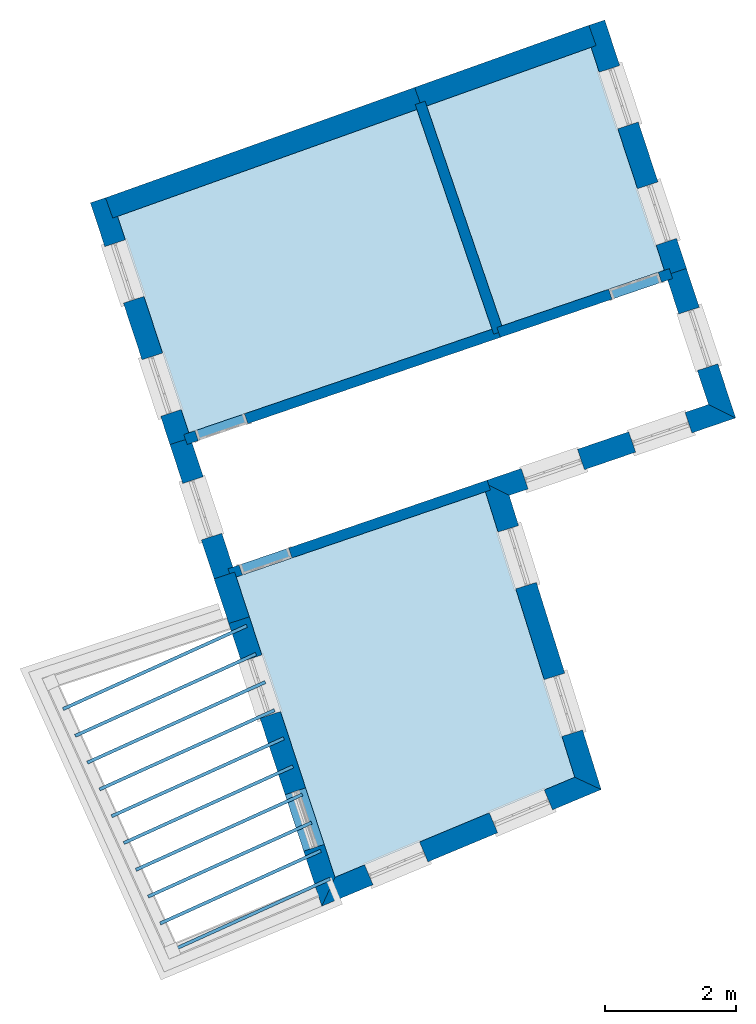
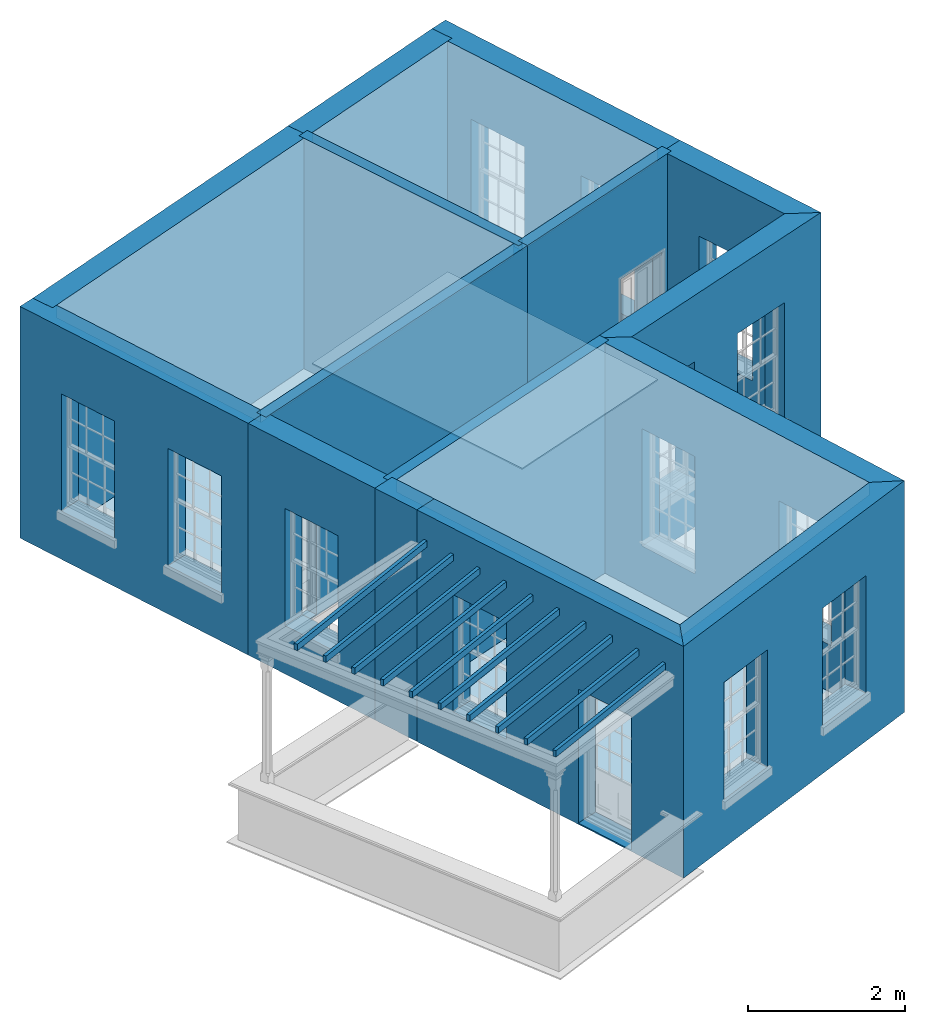
# One storey, part 1 of 10: 16 slabs, 15 walls, 17 openings.
"""IFC2X3 building model written with IfcOpenShell, lengths in metres."""

import ifcopenshell
import ifcopenshell.guid

model = None  # the IFC model being written
_history = None  # IfcOwnerHistory: only IFC2X3 demands one
_inside = {}  # id of a spatial element -> (the spatial element, [elements in it])
_under = {}  # id of a project, library or spatial element -> (it, [spatial elements below it])
_declared = {}  # id of a project -> (the project, [libraries it declares])
_typed = {}  # id of a type object -> (the type object, [elements of that type])
_made_of = {}  # id of a material, layer set ... -> (it, [elements and type objects made of it])


def new_model(schema):
    """Start an empty IFC model of exactly this schema.

    Asked for "IFC4X3", IfcOpenShell would pick the latest addendum, in which some entities
    have other attributes; the version numbers below select the first issue.
    IFC2X3 requires an IfcOwnerHistory on every rooted entity: one is made here for all.
    """
    global model, _history
    if schema == "IFC4X3":
        model = ifcopenshell.file(schema_version=(4, 3, 0, 0))
    else:
        model = ifcopenshell.file(schema=schema)
    _inside.clear()
    _under.clear()
    _declared.clear()
    _typed.clear()
    _made_of.clear()
    _history = None
    if model.schema == "IFC2X3":
        org = make("IfcOrganization", Name="unknown")
        user = make(
            "IfcPersonAndOrganization",
            ThePerson=make("IfcPerson", FamilyName="unknown"),
            TheOrganization=org,
        )
        app = make(
            "IfcApplication",
            ApplicationDeveloper=org,
            Version="unknown",
            ApplicationFullName="unknown",
            ApplicationIdentifier="unknown",
        )
        _history = make(
            "IfcOwnerHistory",
            OwningUser=user,
            OwningApplication=app,
            ChangeAction="ADDED",
            CreationDate=0,
        )
    return model


def make(cls, **values):
    """One entity of the class cls with the attributes given. An attribute that is None is left unset."""
    return model.create_entity(
        cls, **{name: value for name, value in values.items() if value is not None}
    )


def rooted(cls, **values):
    """An entity with a GlobalId (a new one), such as an element, a storey or a relation."""
    return make(cls, GlobalId=ifcopenshell.guid.new(), OwnerHistory=_history, **values)


def si_unit(unit_type, name, prefix=None):
    """IfcSIUnit, for example si_unit("LENGTHUNIT", "METRE", prefix="MILLI")."""
    return make("IfcSIUnit", UnitType=unit_type, Prefix=prefix, Name=name)


def assignment(units):
    """IfcUnitAssignment: the units of a project."""
    return None if units is None else make("IfcUnitAssignment", Units=units)


def point(xyz):
    """IfcCartesianPoint."""
    return None if xyz is None else make("IfcCartesianPoint", Coordinates=xyz)


def direction(xyz):
    """IfcDirection."""
    return None if xyz is None else make("IfcDirection", DirectionRatios=xyz)


def frame(location, z_axis=None, x_axis=None):
    """IfcAxis2Placement3D, a coordinate frame: its origin and axes. An axis left out is left unset."""
    return make(
        "IfcAxis2Placement3D",
        Location=point(location),
        Axis=direction(z_axis),
        RefDirection=direction(x_axis),
    )


def origin():
    """The frame at (0, 0, 0) with its axes left unset."""
    return frame((0.0, 0.0, 0.0))


def place(relative_to, where):
    """IfcLocalPlacement: puts the frame where relative to a parent placement (None: the world)."""
    return make(
        "IfcLocalPlacement", PlacementRelTo=relative_to, RelativePlacement=where
    )


def context(
    kind, dimensions, precision=None, world=None, true_north=None, identifier=None
):
    """IfcGeometricRepresentationContext, for example the 3D "Model" context."""
    return make(
        "IfcGeometricRepresentationContext",
        ContextIdentifier=identifier,
        ContextType=kind,
        CoordinateSpaceDimension=dimensions,
        Precision=precision,
        WorldCoordinateSystem=world,
        TrueNorth=true_north,
    )


def subcontext(parent, identifier, kind, view, scale=None):
    """IfcGeometricRepresentationSubContext, for example "Body" below "Model"."""
    return make(
        "IfcGeometricRepresentationSubContext",
        ContextIdentifier=identifier,
        ContextType=kind,
        ParentContext=parent,
        TargetScale=scale,
        TargetView=view,
    )


def project(units=None, contexts=None):
    """IfcProject with its units and contexts."""
    return rooted(
        "IfcProject",
        Name="project",
        RepresentationContexts=contexts,
        UnitsInContext=assignment(units),
    )


def spatial(cls, under=None, at=None, **own):
    """A site, building, storey or space (cls), placed at a placement, below another one or the project."""
    s = rooted(cls, ObjectPlacement=at, **own)
    if under is not None:
        _under.setdefault(under.id(), (under, []))[1].append(s)
    return s


def polyline(points):
    """IfcPolyline through the points."""
    return make("IfcPolyline", Points=[point(p) for p in points])


def outline(outer, holes=None, kind="AREA"):
    """IfcArbitraryClosedProfileDef: a profile drawn as a closed curve; with holes, ...WithVoids."""
    if holes is None:
        return make("IfcArbitraryClosedProfileDef", ProfileType=kind, OuterCurve=outer)
    return make(
        "IfcArbitraryProfileDefWithVoids",
        ProfileType=kind,
        OuterCurve=outer,
        InnerCurves=holes,
    )


def extrude(swept, where, along, depth):
    """IfcExtrudedAreaSolid: the profile swept, set in the frame where, extruded along a direction by depth."""
    return make(
        "IfcExtrudedAreaSolid",
        SweptArea=swept,
        Position=where,
        ExtrudedDirection=direction(along),
        Depth=depth,
    )


def shape(context_of_items, identifier, shape_type, items):
    """IfcShapeRepresentation: the items that make up one representation, for example the "Body"."""
    return make(
        "IfcShapeRepresentation",
        ContextOfItems=context_of_items,
        RepresentationIdentifier=identifier,
        RepresentationType=shape_type,
        Items=items,
    )


def material(Name=None, Category=None):
    """IfcMaterial."""
    return make("IfcMaterial", Name=Name, Category=Category)


def layer(
    of_material, thickness, ventilated=None, Name=None, Category=None, Priority=None
):
    """IfcMaterialLayer: one layer of a wall or slab, of a material (None: an air gap)."""
    return make(
        "IfcMaterialLayer",
        Material=of_material,
        LayerThickness=thickness,
        IsVentilated=ventilated,
        Name=Name,
        Category=Category,
        Priority=Priority,
    )


def layer_set(layers, Name=None):
    """IfcMaterialLayerSet."""
    return make("IfcMaterialLayerSet", MaterialLayers=layers, LayerSetName=Name)


def layer_usage(for_layer_set, set_direction, sense, offset, extent=None):
    """IfcMaterialLayerSetUsage: how a layer set lies in its element."""
    return make(
        "IfcMaterialLayerSetUsage",
        ForLayerSet=for_layer_set,
        LayerSetDirection=set_direction,
        DirectionSense=sense,
        OffsetFromReferenceLine=offset,
        ReferenceExtent=extent,
    )


def made_of(thing, what):
    """Note that an element or type object is made of a material, layer set ...; save() writes the relation."""
    if what is not None:
        _made_of.setdefault(what.id(), (what, []))[1].append(thing)
    return thing


def element(
    cls,
    number,
    at=None,
    inside=None,
    cuts=None,
    type_object=None,
    material=None,
    context=None,
    identifier="Body",
    shape_type=None,
    held_by="IfcProductDefinitionShape",
    body=None,
    shapes=None,
    **own,
):
    """One element of the class cls, such as IfcWall. Its Tag is "e" and its number.

    at: its placement. inside: the storey or other place that contains it. cuts: it is an
    opening in that element (IfcRelVoidsElement). A single representation is given by context,
    identifier, shape_type and body (its items); several are given by shapes. held_by: the class
    of the entity that holds the representations. save() writes the other relations.
    """
    e = rooted(cls, Tag="e%d" % number, ObjectPlacement=at, **own)
    if body is not None:
        shapes = [shape(context, identifier, shape_type, body)]
    if shapes is not None:
        e.Representation = make(held_by, Representations=shapes)
    if inside is not None:
        _inside.setdefault(inside.id(), (inside, []))[1].append(e)
    if cuts is not None:
        rooted(
            "IfcRelVoidsElement", RelatingBuildingElement=cuts, RelatedOpeningElement=e
        )
    if type_object is not None:
        _typed.setdefault(type_object.id(), (type_object, []))[1].append(e)
    return made_of(e, material)


def aggregate(whole, parts):
    """IfcRelAggregates: a whole, such as a stair, and the parts it consists of."""
    return rooted("IfcRelAggregates", RelatingObject=whole, RelatedObjects=parts)


def save(model, path):
    """Write the relations noted so far, then the file.

    IfcRelAggregates (storeys below a building ...), IfcRelContainedInSpatialStructure (elements
    in a storey), IfcRelDefinesByType, IfcRelAssociatesMaterial and IfcRelDeclares: one each for
    every whole, place, type object, material and project.
    """
    for whole, parts in _under.values():
        aggregate(whole, parts)
    for where, things in _inside.values():
        rooted(
            "IfcRelContainedInSpatialStructure",
            RelatedElements=things,
            RelatingStructure=where,
        )
    for kind, things in _typed.values():
        rooted("IfcRelDefinesByType", RelatedObjects=things, RelatingType=kind)
    for what, things in _made_of.values():
        rooted("IfcRelAssociatesMaterial", RelatedObjects=things, RelatingMaterial=what)
    for by, libraries in _declared.values():
        rooted("IfcRelDeclares", RelatingContext=by, RelatedDefinitions=libraries)
    model.write(path)


model = new_model("IFC2X3")

# Units and contexts
model_context = context("Model", 3, world=origin())
body_context = subcontext(model_context, "Body", "Model", "MODEL_VIEW")
ifc_project = project(units=[si_unit("PLANEANGLEUNIT", "RADIAN"), si_unit("MASSUNIT", "GRAM", prefix="KILO"), si_unit("FORCEUNIT", "NEWTON", prefix="KILO"), si_unit("LENGTHUNIT", "METRE")], contexts=[model_context])

# Site, building, storey
site_placement = place(None, origin())
site = spatial("IfcSite", under=ifc_project, at=site_placement, CompositionType="ELEMENT")
building_placement = place(None, origin())
building = spatial("IfcBuilding", under=site, at=building_placement, Name="Building plot-2", CompositionType="ELEMENT")
storey_placement = place(None, frame((0.0, 0.0, 4.6)))
storey = spatial("IfcBuildingStorey", under=building, at=storey_placement, Name="Floor 1", CompositionType="ELEMENT", Elevation=4.6)

# Slabs
slab_1_placement = place(storey_placement, frame((0.0, 0.0, 3.4)))
element("IfcSlab", 1, at=slab_1_placement, inside=storey, Name="Slab", ObjectType="Slab", PredefinedType="FLOOR", context=body_context, shape_type="SweptSolid", body=[
    extrude(outline(polyline([(33.5290367019011, 35.1153902275638), (36.0140572668092, 35.9650779065647), (34.8926468518954, 39.3738287255257), (32.3797022245849, 38.4767662751101), (33.5290367019011, 35.1153902275638)])), origin(), (0.0, 0.0, 1.0), 0.2),
])
slab_2_placement = place(storey_placement, frame((0.0, 0.0, 3.4)))
element("IfcSlab", 2, at=slab_2_placement, inside=storey, Name="Slab", ObjectType="Slab", PredefinedType="FLOOR", context=body_context, shape_type="SweptSolid", body=[
    extrude(outline(polyline([(30.9770364314834, 26.681595071692), (34.6434756954392, 28.211451652365), (33.2776509706579, 32.5768775648318), (29.4663278228958, 31.2736954644197), (30.9770364314834, 26.681595071692)])), origin(), (0.0, 0.0, 1.0), 0.2),
])
slab_3_placement = place(storey_placement, frame((0.0, 0.0, 3.4)))
element("IfcSlab", 3, at=slab_3_placement, inside=storey, Name="Slab", ObjectType="Slab", PredefinedType="FLOOR", context=body_context, shape_type="SweptSolid", body=[
    extrude(outline(polyline([(28.7410673229935, 33.4782695348257), (33.3776420525997, 35.0636247935088), (32.2290020264794, 38.4229698294896), (27.6518880966078, 36.7890472220676), (28.7410673229935, 33.4782695348257)])), origin(), (0.0, 0.0, 1.0), 0.2),
])
slab_4_placement = place(storey_placement, frame((0.0, 0.0, 3.1)))
element("IfcSlab", 4, at=slab_4_placement, inside=storey, Name="Slab", ObjectType="Slab", PredefinedType="FLOOR", context=body_context, shape_type="SweptSolid", body=[
    extrude(outline(polyline([(26.8073450307166, 29.2772545120461), (26.8279720766327, 29.2317075585061), (29.6380417777998, 30.5043159823061), (29.6174147318837, 30.5498629358461), (26.8073450307166, 29.2772545120461)])), origin(), (0.0, 0.0, 1.0), 0.1),
])
slab_5_placement = place(storey_placement, frame((0.0, 0.0, 3.1)))
element("IfcSlab", 5, at=slab_5_placement, inside=storey, Name="Slab", ObjectType="Slab", PredefinedType="FLOOR", context=body_context, shape_type="SweptSolid", body=[
    extrude(outline(polyline([(26.9929884439615, 28.8673319301861), (27.0136154898777, 28.8217849766461), (29.7794835122652, 30.0743755949313), (29.7588564663491, 30.1199225484713), (26.9929884439615, 28.8673319301861)])), origin(), (0.0, 0.0, 1.0), 0.1),
])
slab_6_placement = place(storey_placement, frame((0.0, 0.0, 3.1)))
element("IfcSlab", 6, at=slab_6_placement, inside=storey, Name="Slab", ObjectType="Slab", PredefinedType="FLOOR", context=body_context, shape_type="SweptSolid", body=[
    extrude(outline(polyline([(27.1786318572065, 28.4574093483261), (27.1992589031226, 28.4118623947861), (29.9209252467306, 29.6444352075565), (29.9002982008145, 29.6899821610965), (27.1786318572065, 28.4574093483261)])), origin(), (0.0, 0.0, 1.0), 0.1),
])
slab_7_placement = place(storey_placement, frame((0.0, 0.0, 3.1)))
element("IfcSlab", 7, at=slab_7_placement, inside=storey, Name="Slab", ObjectType="Slab", PredefinedType="FLOOR", context=body_context, shape_type="SweptSolid", body=[
    extrude(outline(polyline([(27.3642752704514, 28.0474867664661), (27.3849023163675, 28.0019398129261), (30.062366981196, 29.2144948201818), (30.0417399352799, 29.2600417737218), (27.3642752704514, 28.0474867664661)])), origin(), (0.0, 0.0, 1.0), 0.1),
])
slab_8_placement = place(storey_placement, frame((0.0, 0.0, 3.1)))
element("IfcSlab", 8, at=slab_8_placement, inside=storey, Name="Slab", ObjectType="Slab", PredefinedType="FLOOR", context=body_context, shape_type="SweptSolid", body=[
    extrude(outline(polyline([(27.5499186836964, 27.6375641846061), (27.5705457296125, 27.5920172310661), (30.2038087156614, 28.784554432807), (30.1831816697453, 28.830101386347), (27.5499186836964, 27.6375641846061)])), origin(), (0.0, 0.0, 1.0), 0.1),
])
slab_9_placement = place(storey_placement, frame((0.0, 0.0, 3.1)))
element("IfcSlab", 9, at=slab_9_placement, inside=storey, Name="Slab", ObjectType="Slab", PredefinedType="FLOOR", context=body_context, shape_type="SweptSolid", body=[
    extrude(outline(polyline([(27.7355620969413, 27.2276416027461), (27.7561891428574, 27.1820946492061), (30.3452504501268, 28.3546140454322), (30.3246234042107, 28.4001609989722), (27.7355620969413, 27.2276416027461)])), origin(), (0.0, 0.0, 1.0), 0.1),
])
slab_10_placement = place(storey_placement, frame((0.0, 0.0, 3.1)))
element("IfcSlab", 10, at=slab_10_placement, inside=storey, Name="Slab", ObjectType="Slab", PredefinedType="FLOOR", context=body_context, shape_type="SweptSolid", body=[
    extrude(outline(polyline([(27.9212055101863, 26.8177190208861), (27.9418325561024, 26.7721720673461), (30.4866921845922, 27.9246736580574), (30.4660651386761, 27.9702206115974), (27.9212055101863, 26.8177190208861)])), origin(), (0.0, 0.0, 1.0), 0.1),
])
slab_11_placement = place(storey_placement, frame((0.0, 0.0, 3.1)))
element("IfcSlab", 11, at=slab_11_placement, inside=storey, Name="Slab", ObjectType="Slab", PredefinedType="FLOOR", context=body_context, shape_type="SweptSolid", body=[
    extrude(outline(polyline([(28.1068489234312, 26.4077964390261), (28.1274759693473, 26.3622494854861), (30.6281339190576, 27.4947332706826), (30.6075068731415, 27.5402802242226), (28.1068489234312, 26.4077964390261)])), origin(), (0.0, 0.0, 1.0), 0.1),
])
slab_12_placement = place(storey_placement, frame((0.0, 0.0, 3.1)))
element("IfcSlab", 12, at=slab_12_placement, inside=storey, Name="Slab", ObjectType="Slab", PredefinedType="FLOOR", context=body_context, shape_type="SweptSolid", body=[
    extrude(outline(polyline([(28.2924923366762, 25.9978738571661), (28.3131193825923, 25.9523269036261), (30.7695756535229, 27.0647928833078), (30.7489486076068, 27.1103398368478), (28.2924923366762, 25.9978738571661)])), origin(), (0.0, 0.0, 1.0), 0.1),
])
slab_13_placement = place(storey_placement, frame((0.0, 0.0, 3.1)))
element("IfcSlab", 13, at=slab_13_placement, inside=storey, Name="Slab", ObjectType="Slab", PredefinedType="FLOOR", context=body_context, shape_type="SweptSolid", body=[
    extrude(outline(polyline([(28.4781357499211, 25.5879512753061), (28.4987627958372, 25.5424043217661), (30.9110173879883, 26.634852495933), (30.8903903420722, 26.680399449473), (28.4781357499211, 25.5879512753061)])), origin(), (0.0, 0.0, 1.0), 0.1),
])
slab_14_placement = place(storey_placement, origin())
element("IfcSlab", 14, at=slab_14_placement, inside=storey, Name="Slab", ObjectType="Slab", PredefinedType="FLOOR", context=body_context, shape_type="SweptSolid", body=[
    extrude(outline(polyline([(33.5290367019011, 35.1153902275638), (36.0140572668092, 35.9650779065647), (34.8926468518954, 39.3738287255257), (32.3797022245849, 38.4767662751101), (33.5290367019011, 35.1153902275638)])), origin(), (0.0, 0.0, 1.0), 0.02),
])
slab_15_placement = place(storey_placement, origin())
element("IfcSlab", 15, at=slab_15_placement, inside=storey, Name="Slab", ObjectType="Slab", PredefinedType="FLOOR", context=body_context, shape_type="SweptSolid", body=[
    extrude(outline(polyline([(30.9770364314834, 26.681595071692), (34.6434756954392, 28.211451652365), (33.2776509706579, 32.5768775648318), (29.4663278228958, 31.2736954644197), (30.9770364314834, 26.681595071692)])), origin(), (0.0, 0.0, 1.0), 0.02),
])
slab_16_placement = place(storey_placement, origin())
element("IfcSlab", 16, at=slab_16_placement, inside=storey, Name="Slab", ObjectType="Slab", PredefinedType="FLOOR", context=body_context, shape_type="SweptSolid", body=[
    extrude(outline(polyline([(28.7410673229935, 33.4782695348257), (33.3776420525997, 35.0636247935088), (32.2290020264794, 38.4229698294896), (27.6518880966078, 36.7890472220676), (28.7410673229935, 33.4782695348257)])), origin(), (0.0, 0.0, 1.0), 0.02),
])

# Wall, openings
ifc_material_1 = material(Name="Masonry")
ifc_layer_1 = layer(ifc_material_1, 0.33, ventilated=False)
ifc_layer_set_1 = layer_set([ifc_layer_1], Name="My Wall")
ifc_layer_usage_1 = layer_usage(ifc_layer_set_1, "AXIS2", "NEGATIVE", 0.08)
wall_1_placement = place(storey_placement, origin())
wall_1 = element("IfcWallStandardCase", 17, at=wall_1_placement, inside=storey, material=ifc_layer_usage_1, Name="exterior", context=body_context, shape_type="SweptSolid", body=[
    extrude(outline(polyline([(27.5493804790374, 37.1006395888727), (27.2359079930561, 36.9975134499325), (28.4528876869268, 33.2982607294562), (28.7663601729081, 33.4013868683963), (27.5493804790374, 37.1006395888727)])), origin(), (0.0, 0.0, 1.0), 3.6),
])
opening_1_placement = place(storey_placement, frame((0.0, 0.0, 0.75)))
element("IfcOpeningElement", 18, at=opening_1_placement, cuts=wall_1, Name="Opening", ObjectType="Opening", context=body_context, shape_type="SweptSolid", body=[
    extrude(outline(polyline([(27.456558243292, 36.3268029667832), (27.7409363840057, 35.4623788387741), (28.054408869987, 35.5655049777142), (27.7700307292734, 36.4299291057233), (27.456558243292, 36.3268029667832)])), origin(), (0.0, 0.0, 1.0), 1.82),
])
opening_2_placement = place(storey_placement, frame((0.0, 0.0, 0.75)))
element("IfcOpeningElement", 19, at=opening_2_placement, cuts=wall_1, Name="Opening", ObjectType="Opening", context=body_context, shape_type="SweptSolid", body=[
    extrude(outline(polyline([(28.0259851588106, 34.5959161845682), (28.3103632995243, 33.7314920565591), (28.6238357855056, 33.8346181954992), (28.339457644792, 34.6990423235083), (28.0259851588106, 34.5959161845682)])), origin(), (0.0, 0.0, 1.0), 1.82),
])

# Wall, opening
wall_2_placement = place(storey_placement, origin())
wall_2 = element("IfcWallStandardCase", 20, at=wall_2_placement, inside=storey, material=ifc_layer_usage_1, Name="exterior", context=body_context, shape_type="SweptSolid", body=[
    extrude(outline(polyline([(28.7663601729081, 33.4013868683963), (28.4528876869268, 33.2982607294562), (29.1281442502824, 31.2456836062765), (29.4416167362638, 31.3488097452166), (28.7663601729081, 33.4013868683963)])), origin(), (0.0, 0.0, 1.0), 3.6),
])
opening_3_placement = place(storey_placement, frame((0.0, 0.0, 0.75)))
element("IfcOpeningElement", 21, at=opening_3_placement, cuts=wall_2, Name="Opening", ObjectType="Opening", context=body_context, shape_type="SweptSolid", body=[
    extrude(outline(polyline([(28.6483268982478, 32.7041842318709), (28.9327050389614, 31.8397601038618), (29.2461775249427, 31.9428862428019), (28.9617993842291, 32.807310370811), (28.6483268982478, 32.7041842318709)])), origin(), (0.0, 0.0, 1.0), 1.82),
])

# Wall
wall_3_placement = place(storey_placement, origin())
element("IfcWallStandardCase", 22, at=wall_3_placement, inside=storey, material=ifc_layer_usage_1, Name="exterior", context=body_context, shape_type="SweptSolid", body=[
    extrude(outline(polyline([(29.4416167362638, 31.3488097452166), (29.1281442502824, 31.2456836062765), (29.3530055275266, 30.5621728659042), (29.666478013508, 30.6652990048443), (29.4416167362638, 31.3488097452166)])), origin(), (0.0, 0.0, 1.0), 3.6),
])

# Wall, openings
wall_4_placement = place(storey_placement, origin())
wall_4 = element("IfcWallStandardCase", 23, at=wall_4_placement, inside=storey, material=ifc_layer_usage_1, Name="exterior", context=body_context, shape_type="SweptSolid", body=[
    extrude(outline(polyline([(29.666478013508, 30.6652990048443), (29.3530055275266, 30.5621728659042), (30.7750053905993, 26.2397204137535), (30.9770364314834, 26.681595071692), (29.666478013508, 30.6652990048443)])), origin(), (0.0, 0.0, 1.0), 3.6),
])
opening_4_placement = place(storey_placement, frame((0.0, 0.0, 0.75)))
element("IfcOpeningElement", 24, at=opening_4_placement, cuts=wall_4, Name="Opening", ObjectType="Opening", context=body_context, shape_type="SweptSolid", body=[
    extrude(outline(polyline([(29.5452100886393, 29.977928733348), (29.8295882293529, 29.1135046053389), (30.1430607153342, 29.2166307442791), (29.8586825746206, 30.0810548722881), (29.5452100886393, 29.977928733348)])), origin(), (0.0, 0.0, 1.0), 1.82),
])
opening_5_placement = place(storey_placement, frame((0.0, 0.0, 0.0199999999999996)))
element("IfcOpeningElement", 25, at=opening_5_placement, cuts=wall_4, Name="Opening", ObjectType="Opening", context=body_context, shape_type="SweptSolid", body=[
    extrude(outline(polyline([(30.2139973515782, 27.9450163402266), (30.4983754922918, 27.0805922122175), (30.8118479782731, 27.1837183511577), (30.5274698375595, 28.0481424791667), (30.2139973515782, 27.9450163402266)])), origin(), (0.0, 0.0, 1.0), 2.08),
])

wall_5_placement = place(storey_placement, origin())
wall_5 = element("IfcWallStandardCase", 26, at=wall_5_placement, inside=storey, material=ifc_layer_usage_1, Name="exterior", context=body_context, shape_type="SweptSolid", body=[
    extrude(outline(polyline([(30.9770364314834, 26.681595071692), (30.7750053905993, 26.2397204137535), (35.0482793359076, 28.0227845246247), (34.6434756954392, 28.211451652365), (30.9770364314834, 26.681595071692)])), origin(), (0.0, 0.0, 1.0), 3.6),
])
opening_6_placement = place(storey_placement, frame((0.0, 0.0, 0.75)))
element("IfcOpeningElement", 27, at=opening_6_placement, cuts=wall_5, Name="Opening", ObjectType="Opening", context=body_context, shape_type="SweptSolid", body=[
    extrude(outline(polyline([(31.5578056947478, 26.5663512701344), (32.3976288299351, 26.9167754439639), (32.2705519317332, 27.2213266907901), (31.4307287965459, 26.8709025169606), (31.5578056947478, 26.5663512701344)])), origin(), (0.0, 0.0, 1.0), 1.82),
])
opening_7_placement = place(storey_placement, frame((0.0, 0.0, 0.75)))
element("IfcOpeningElement", 28, at=opening_7_placement, cuts=wall_5, Name="Opening", ObjectType="Opening", context=body_context, shape_type="SweptSolid", body=[
    extrude(outline(polyline([(33.4645810456775, 27.3619713823131), (34.3044041808648, 27.7123955561426), (34.1773272826629, 28.0169468029688), (33.3375041474755, 27.6665226291393), (33.4645810456775, 27.3619713823131)])), origin(), (0.0, 0.0, 1.0), 1.82),
])

wall_6_placement = place(storey_placement, origin())
wall_6 = element("IfcWallStandardCase", 29, at=wall_6_placement, inside=storey, material=ifc_layer_usage_1, Name="exterior", context=body_context, shape_type="SweptSolid", body=[
    extrude(outline(polyline([(34.6434756954392, 28.211451652365), (35.0482793359076, 28.0227845246247), (33.6407893243681, 32.5213803227765), (33.2298586094676, 32.7296307023118), (34.6434756954392, 28.211451652365)])), origin(), (0.0, 0.0, 1.0), 3.6),
])
opening_8_placement = place(storey_placement, frame((0.0, 0.0, 0.75)))
element("IfcOpeningElement", 30, at=opening_8_placement, cuts=wall_6, Name="Opening", ObjectType="Opening", context=body_context, shape_type="SweptSolid", body=[
    extrude(outline(polyline([(34.763034359332, 28.9344797001121), (34.4913088580484, 29.8029641570554), (34.1763639450909, 29.7044263379086), (34.4480894463745, 28.8359418809653), (34.763034359332, 28.9344797001121)])), origin(), (0.0, 0.0, 1.0), 1.82),
])
opening_9_placement = place(storey_placement, frame((0.0, 0.0, 0.75)))
element("IfcOpeningElement", 31, at=opening_9_placement, cuts=wall_6, Name="Opening", ObjectType="Opening", context=body_context, shape_type="SweptSolid", body=[
    extrude(outline(polyline([(34.0569684920349, 31.1911954975952), (33.7852429907513, 32.0596799545385), (33.4702980777938, 31.9611421353917), (33.7420235790774, 31.0926576784484), (34.0569684920349, 31.1911954975952)])), origin(), (0.0, 0.0, 1.0), 1.82),
])

wall_7_placement = place(storey_placement, origin())
wall_7 = element("IfcWallStandardCase", 32, at=wall_7_placement, inside=storey, material=ifc_layer_usage_1, Name="exterior", context=body_context, shape_type="SweptSolid", body=[
    extrude(outline(polyline([(33.2298586094676, 32.7296307023118), (33.6407893243681, 32.5213803227765), (37.1047195485034, 33.7057805140381), (36.6893138301649, 33.9125007833851), (33.2298586094676, 32.7296307023118)])), origin(), (0.0, 0.0, 1.0), 3.6),
])
opening_10_placement = place(storey_placement, frame((0.0, 0.0, 0.75)))
element("IfcOpeningElement", 33, at=opening_10_placement, cuts=wall_7, Name="Opening", ObjectType="Opening", context=body_context, shape_type="SweptSolid", body=[
    extrude(outline(polyline([(33.9307807744007, 32.620535301849), (34.7918378423025, 32.9149512080368), (34.6850716345641, 33.2272026722209), (33.8240145666623, 32.9327867660332), (33.9307807744007, 32.620535301849)])), origin(), (0.0, 0.0, 1.0), 1.82),
])
opening_11_placement = place(storey_placement, frame((0.0, 0.0, 0.75)))
element("IfcOpeningElement", 34, at=opening_11_placement, cuts=wall_7, Name="Opening", ObjectType="Opening", context=body_context, shape_type="SweptSolid", body=[
    extrude(outline(polyline([(35.5752381859879, 33.1828144318484), (36.4362952538897, 33.4772303380362), (36.3295290461513, 33.7894818022204), (35.4684719782495, 33.4950658960326), (35.5752381859879, 33.1828144318484)])), origin(), (0.0, 0.0, 1.0), 1.82),
])

# Wall, opening
wall_8_placement = place(storey_placement, origin())
wall_8 = element("IfcWallStandardCase", 35, at=wall_8_placement, inside=storey, material=ifc_layer_usage_1, Name="exterior", context=body_context, shape_type="SweptSolid", body=[
    extrude(outline(polyline([(36.6893138301649, 33.9125007833851), (37.1047195485034, 33.7057805140381), (36.3522408394225, 35.9930897647079), (36.0387683534412, 35.8899636257678), (36.6893138301649, 33.9125007833851)])), origin(), (0.0, 0.0, 1.0), 3.6),
])
opening_12_placement = place(storey_placement, frame((0.0, 0.0, 0.75)))
element("IfcOpeningElement", 36, at=opening_12_placement, cuts=wall_8, Name="Opening", ObjectType="Opening", context=body_context, shape_type="SweptSolid", body=[
    extrude(outline(polyline([(36.8320581914572, 34.5345891391136), (36.5476800507436, 35.3990132671227), (36.2342075647623, 35.2958871281825), (36.5185857054759, 34.4314630001735), (36.8320581914572, 34.5345891391136)])), origin(), (0.0, 0.0, 1.0), 1.82),
])

# Wall, openings
wall_9_placement = place(storey_placement, origin())
wall_9 = element("IfcWallStandardCase", 37, at=wall_9_placement, inside=storey, material=ifc_layer_usage_1, Name="exterior", context=body_context, shape_type="SweptSolid", body=[
    extrude(outline(polyline([(36.0387683534412, 35.8899636257678), (36.3522408394225, 35.9930897647079), (35.1023589867895, 39.7923551648735), (34.7888865008082, 39.6892290259334), (36.0387683534412, 35.8899636257678)])), origin(), (0.0, 0.0, 1.0), 3.6),
])
opening_13_placement = place(storey_placement, frame((0.0, 0.0, 0.75)))
element("IfcOpeningElement", 38, at=opening_13_placement, cuts=wall_9, Name="Opening", ObjectType="Opening", context=body_context, shape_type="SweptSolid", body=[
    extrude(outline(polyline([(36.2014909123295, 36.4513242617331), (35.9171127716158, 37.3157483897422), (35.6036402856345, 37.2126222508021), (35.8880184263481, 36.348198122793), (36.2014909123295, 36.4513242617331)])), origin(), (0.0, 0.0, 1.0), 1.82),
])
opening_14_placement = place(storey_placement, frame((0.0, 0.0, 0.75)))
element("IfcOpeningElement", 39, at=opening_14_placement, cuts=wall_9, Name="Opening", ObjectType="Opening", context=body_context, shape_type="SweptSolid", body=[
    extrude(outline(polyline([(35.6156129174297, 38.2322173837927), (35.331234776716, 39.0966415118018), (35.0177622907347, 38.9935153728617), (35.3021404314483, 38.1290912448526), (35.6156129174297, 38.2322173837927)])), origin(), (0.0, 0.0, 1.0), 1.82),
])

# Walls
wall_10_placement = place(storey_placement, origin())
element("IfcWallStandardCase", 40, at=wall_10_placement, inside=storey, material=ifc_layer_usage_1, Name="party", context=body_context, shape_type="SweptSolid", body=[
    extrude(outline(polyline([(34.9699014962567, 39.401406826461), (34.858956310201, 39.7121980195329), (32.1944176961582, 38.761020061864), (32.3053628822139, 38.4502288687921), (34.9699014962567, 39.401406826461)])), origin(), (0.0, 0.0, 1.0), 3.6),
])
wall_11_placement = place(storey_placement, origin())
element("IfcWallStandardCase", 41, at=wall_11_placement, inside=storey, material=ifc_layer_usage_1, Name="party", context=body_context, shape_type="SweptSolid", body=[
    extrude(outline(polyline([(32.3053628822139, 38.4502288687921), (32.1944176961582, 38.761020061864), (27.4674636285605, 37.0736080302588), (27.5784088146162, 36.7628168371869), (32.3053628822139, 38.4502288687921)])), origin(), (0.0, 0.0, 1.0), 3.6),
])

# Wall, opening
ifc_material_2 = material(Name="Masonry")
ifc_layer_2 = layer(ifc_material_2, 0.16, ventilated=False)
ifc_layer_set_2 = layer_set([ifc_layer_2], Name="My Wall")
ifc_layer_usage_2 = layer_usage(ifc_layer_set_2, "AXIS2", "NEGATIVE", 0.08)
wall_12_placement = place(storey_placement, origin())
wall_12 = element("IfcWallStandardCase", 42, at=wall_12_placement, inside=storey, material=ifc_layer_usage_2, Name="interior", context=body_context, shape_type="SweptSolid", body=[
    extrude(outline(polyline([(33.3553608937437, 32.6034484371677), (33.3035954596887, 32.7548430864691), (29.3397406893014, 31.3995067937606), (29.3915061233564, 31.2481121444592), (33.3553608937437, 32.6034484371677)])), origin(), (0.0, 0.0, 1.0), 3.6),
])
opening_15_placement = place(storey_placement, frame((0.0, 0.0, 0.0199999999999996)))
element("IfcOpeningElement", 43, at=opening_15_placement, cuts=wall_12, Name="Opening", ObjectType="Opening", context=body_context, shape_type="SweptSolid", body=[
    extrude(outline(polyline([(30.2670329162725, 31.7165700773475), (29.5100596697655, 31.4577429070725), (29.5618251038205, 31.3063482577711), (30.3187983503275, 31.5651754280461), (30.2670329162725, 31.7165700773475)])), origin(), (0.0, 0.0, 1.0), 2.1),
])

wall_13_placement = place(storey_placement, origin())
wall_13 = element("IfcWallStandardCase", 44, at=wall_13_placement, inside=storey, material=ifc_layer_usage_2, Name="interior", context=body_context, shape_type="SweptSolid", body=[
    extrude(outline(polyline([(33.5051048113054, 34.9381128612349), (33.4533393772504, 35.0895075105363), (28.6644841259457, 33.4520839169403), (28.7162495600007, 33.3006892676389), (33.5051048113054, 34.9381128612349)])), origin(), (0.0, 0.0, 1.0), 3.6),
])
opening_16_placement = place(storey_placement, frame((0.0, 0.0, 0.0199999999999996)))
element("IfcOpeningElement", 45, at=opening_16_placement, cuts=wall_13, Name="Opening", ObjectType="Opening", context=body_context, shape_type="SweptSolid", body=[
    extrude(outline(polyline([(29.5917763529169, 33.7691472005271), (28.8348031064098, 33.5103200302522), (28.8865685404648, 33.3589253809508), (29.6435417869719, 33.6177525512257), (29.5917763529169, 33.7691472005271)])), origin(), (0.0, 0.0, 1.0), 2.1),
])

wall_14_placement = place(storey_placement, origin())
wall_14 = element("IfcWallStandardCase", 46, at=wall_14_placement, inside=storey, material=ifc_layer_usage_2, Name="interior", context=body_context, shape_type="SweptSolid", body=[
    extrude(outline(polyline([(33.4533393772504, 35.0895075105363), (33.5051048113054, 34.9381128612349), (36.1406444004036, 35.8392665772238), (36.0888789663486, 35.9906612265252), (33.4533393772504, 35.0895075105363)])), origin(), (0.0, 0.0, 1.0), 3.6),
])
opening_17_placement = place(storey_placement, frame((0.0, 0.0, 0.0199999999999996)))
element("IfcOpeningElement", 47, at=opening_17_placement, cuts=wall_14, Name="Opening", ObjectType="Opening", context=body_context, shape_type="SweptSolid", body=[
    extrude(outline(polyline([(35.2133521734325, 35.5222032936369), (35.9703254199395, 35.7810304639119), (35.9185599858845, 35.9324251132133), (35.1615867393775, 35.6735979429383), (35.2133521734325, 35.5222032936369)])), origin(), (0.0, 0.0, 1.0), 2.1),
])

# Wall
wall_15_placement = place(storey_placement, origin())
element("IfcWallStandardCase", 48, at=wall_15_placement, inside=storey, material=ifc_layer_usage_2, Name="interior", context=body_context, shape_type="SweptSolid", body=[
    extrude(outline(polyline([(33.4035247696272, 34.9879274688581), (33.5549194189286, 35.0396929029131), (32.3541644041844, 38.5514549053522), (32.202769754883, 38.4996894712972), (33.4035247696272, 34.9879274688581)])), origin(), (0.0, 0.0, 1.0), 3.6),
])

save(model, "model.ifc")
